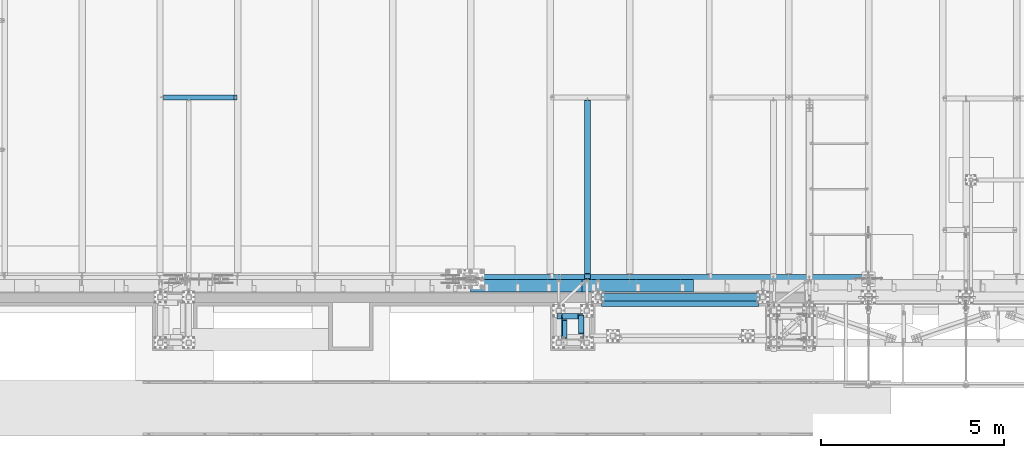
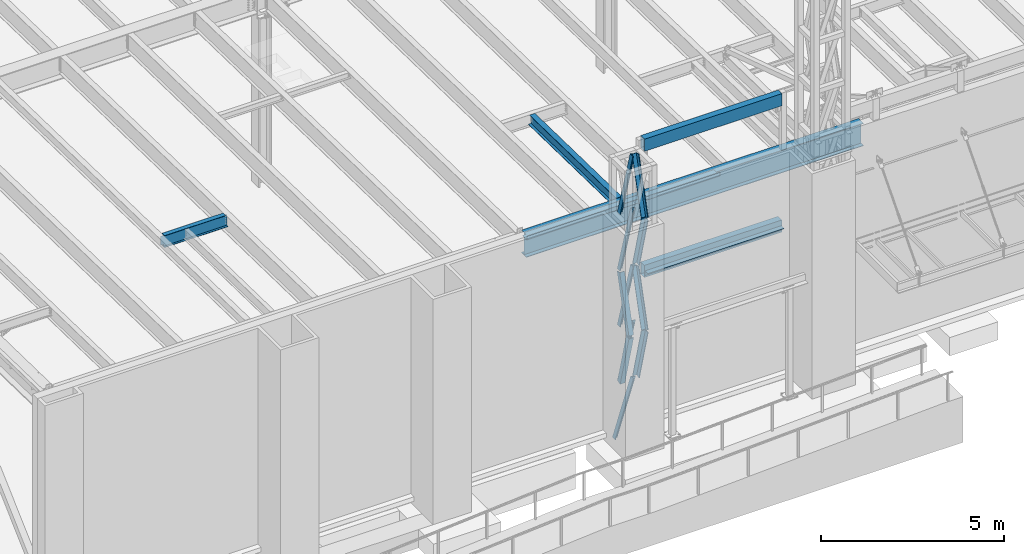
# One storey, part 1039 of 1763: 11 members, 8 beams, 6 elements without a shape of their own.
"""IFC2X3 building model written with IfcOpenShell, lengths in millimetres."""

import ifcopenshell
import ifcopenshell.guid

model = None  # the IFC model being written
_history = None  # IfcOwnerHistory: only IFC2X3 demands one
_inside = {}  # id of a spatial element -> (the spatial element, [elements in it])
_under = {}  # id of a project, library or spatial element -> (it, [spatial elements below it])
_declared = {}  # id of a project -> (the project, [libraries it declares])
_typed = {}  # id of a type object -> (the type object, [elements of that type])
_made_of = {}  # id of a material, layer set ... -> (it, [elements and type objects made of it])


def new_model(schema):
    """Start an empty IFC model of exactly this schema.

    Asked for "IFC4X3", IfcOpenShell would pick the latest addendum, in which some entities
    have other attributes; the version numbers below select the first issue.
    IFC2X3 requires an IfcOwnerHistory on every rooted entity: one is made here for all.
    """
    global model, _history
    if schema == "IFC4X3":
        model = ifcopenshell.file(schema_version=(4, 3, 0, 0))
    else:
        model = ifcopenshell.file(schema=schema)
    _inside.clear()
    _under.clear()
    _declared.clear()
    _typed.clear()
    _made_of.clear()
    _history = None
    if model.schema == "IFC2X3":
        org = make("IfcOrganization", Name="unknown")
        user = make(
            "IfcPersonAndOrganization",
            ThePerson=make("IfcPerson", FamilyName="unknown"),
            TheOrganization=org,
        )
        app = make(
            "IfcApplication",
            ApplicationDeveloper=org,
            Version="unknown",
            ApplicationFullName="unknown",
            ApplicationIdentifier="unknown",
        )
        _history = make(
            "IfcOwnerHistory",
            OwningUser=user,
            OwningApplication=app,
            ChangeAction="ADDED",
            CreationDate=0,
        )
    return model


def make(cls, **values):
    """One entity of the class cls with the attributes given. An attribute that is None is left unset."""
    return model.create_entity(
        cls, **{name: value for name, value in values.items() if value is not None}
    )


def rooted(cls, **values):
    """An entity with a GlobalId (a new one), such as an element, a storey or a relation."""
    return make(cls, GlobalId=ifcopenshell.guid.new(), OwnerHistory=_history, **values)


def si_unit(unit_type, name, prefix=None):
    """IfcSIUnit, for example si_unit("LENGTHUNIT", "METRE", prefix="MILLI")."""
    return make("IfcSIUnit", UnitType=unit_type, Prefix=prefix, Name=name)


def assignment(units):
    """IfcUnitAssignment: the units of a project."""
    return None if units is None else make("IfcUnitAssignment", Units=units)


def point(xyz):
    """IfcCartesianPoint."""
    return None if xyz is None else make("IfcCartesianPoint", Coordinates=xyz)


def direction(xyz):
    """IfcDirection."""
    return None if xyz is None else make("IfcDirection", DirectionRatios=xyz)


def frame(location, z_axis=None, x_axis=None):
    """IfcAxis2Placement3D, a coordinate frame: its origin and axes. An axis left out is left unset."""
    return make(
        "IfcAxis2Placement3D",
        Location=point(location),
        Axis=direction(z_axis),
        RefDirection=direction(x_axis),
    )


def origin_with_axes():
    """The frame at (0, 0, 0) with the z axis (0, 0, 1) and the x axis (1, 0, 0) written out."""
    return frame((0.0, 0.0, 0.0), z_axis=(0.0, 0.0, 1.0), x_axis=(1.0, 0.0, 0.0))


def place(relative_to, where):
    """IfcLocalPlacement: puts the frame where relative to a parent placement (None: the world)."""
    return make(
        "IfcLocalPlacement", PlacementRelTo=relative_to, RelativePlacement=where
    )


def context(
    kind, dimensions, precision=None, world=None, true_north=None, identifier=None
):
    """IfcGeometricRepresentationContext, for example the 3D "Model" context."""
    return make(
        "IfcGeometricRepresentationContext",
        ContextIdentifier=identifier,
        ContextType=kind,
        CoordinateSpaceDimension=dimensions,
        Precision=precision,
        WorldCoordinateSystem=world,
        TrueNorth=true_north,
    )


def subcontext(parent, identifier, kind, view, scale=None):
    """IfcGeometricRepresentationSubContext, for example "Body" below "Model"."""
    return make(
        "IfcGeometricRepresentationSubContext",
        ContextIdentifier=identifier,
        ContextType=kind,
        ParentContext=parent,
        TargetScale=scale,
        TargetView=view,
    )


def project(units=None, contexts=None):
    """IfcProject with its units and contexts."""
    return rooted(
        "IfcProject",
        Name="project",
        RepresentationContexts=contexts,
        UnitsInContext=assignment(units),
    )


def spatial(cls, under=None, at=None, **own):
    """A site, building, storey or space (cls), placed at a placement, below another one or the project."""
    s = rooted(cls, ObjectPlacement=at, **own)
    if under is not None:
        _under.setdefault(under.id(), (under, []))[1].append(s)
    return s


def faces_of(points, faces, orient=None, outer=None):
    """IfcFace entities. A face is a list of loops; a loop is a list of indices into points, from 0.

    orient and outer hold one flag for each loop. By default every Orientation is true, the
    first loop of a face is its IfcFaceOuterBound and the others are IfcFaceBound.
    """
    made = []
    for i, loops in enumerate(faces):
        bounds = []
        for j, loop in enumerate(loops):
            is_outer = j == 0 if outer is None else outer[i][j]
            bounds.append(
                make(
                    "IfcFaceOuterBound" if is_outer else "IfcFaceBound",
                    Bound=make("IfcPolyLoop", Polygon=[points[k] for k in loop]),
                    Orientation=True if orient is None else orient[i][j],
                )
            )
        made.append(make("IfcFace", Bounds=bounds))
    return made


def faceted_brep(points, faces, orient=None, outer=None, voids=None):
    """IfcFacetedBrep: a solid bounded by flat faces; with voids (closed shells), ...WithVoids."""
    shared = [point(p) for p in points]
    hull = make("IfcClosedShell", CfsFaces=faces_of(shared, faces, orient, outer))
    if voids is None:
        return make("IfcFacetedBrep", Outer=hull)
    return make(
        "IfcFacetedBrepWithVoids",
        Outer=hull,
        Voids=[
            make(cls, CfsFaces=faces_of(shared, fs, o, b)) for cls, fs, o, b in voids
        ],
    )


def shape(context_of_items, identifier, shape_type, items):
    """IfcShapeRepresentation: the items that make up one representation, for example the "Body"."""
    return make(
        "IfcShapeRepresentation",
        ContextOfItems=context_of_items,
        RepresentationIdentifier=identifier,
        RepresentationType=shape_type,
        Items=items,
    )


def material(Name=None, Category=None):
    """IfcMaterial."""
    return make("IfcMaterial", Name=Name, Category=Category)


def made_of(thing, what):
    """Note that an element or type object is made of a material, layer set ...; save() writes the relation."""
    if what is not None:
        _made_of.setdefault(what.id(), (what, []))[1].append(thing)
    return thing


def type_object(cls, material=None, **own):
    """A type object (cls), such as IfcWallType, which elements share."""
    return made_of(rooted(cls, **own), material)


def element(
    cls,
    number,
    at=None,
    inside=None,
    cuts=None,
    type_object=None,
    material=None,
    context=None,
    identifier="Body",
    shape_type=None,
    held_by="IfcProductDefinitionShape",
    body=None,
    shapes=None,
    **own,
):
    """One element of the class cls, such as IfcWall. Its Tag is "e" and its number.

    at: its placement. inside: the storey or other place that contains it. cuts: it is an
    opening in that element (IfcRelVoidsElement). A single representation is given by context,
    identifier, shape_type and body (its items); several are given by shapes. held_by: the class
    of the entity that holds the representations. save() writes the other relations.
    """
    e = rooted(cls, Tag="e%d" % number, ObjectPlacement=at, **own)
    if body is not None:
        shapes = [shape(context, identifier, shape_type, body)]
    if shapes is not None:
        e.Representation = make(held_by, Representations=shapes)
    if inside is not None:
        _inside.setdefault(inside.id(), (inside, []))[1].append(e)
    if cuts is not None:
        rooted(
            "IfcRelVoidsElement", RelatingBuildingElement=cuts, RelatedOpeningElement=e
        )
    if type_object is not None:
        _typed.setdefault(type_object.id(), (type_object, []))[1].append(e)
    return made_of(e, material)


def aggregate(whole, parts):
    """IfcRelAggregates: a whole, such as a stair, and the parts it consists of."""
    return rooted("IfcRelAggregates", RelatingObject=whole, RelatedObjects=parts)


def save(model, path):
    """Write the relations noted so far, then the file.

    IfcRelAggregates (storeys below a building ...), IfcRelContainedInSpatialStructure (elements
    in a storey), IfcRelDefinesByType, IfcRelAssociatesMaterial and IfcRelDeclares: one each for
    every whole, place, type object, material and project.
    """
    for whole, parts in _under.values():
        aggregate(whole, parts)
    for where, things in _inside.values():
        rooted(
            "IfcRelContainedInSpatialStructure",
            RelatedElements=things,
            RelatingStructure=where,
        )
    for kind, things in _typed.values():
        rooted("IfcRelDefinesByType", RelatedObjects=things, RelatingType=kind)
    for what, things in _made_of.values():
        rooted("IfcRelAssociatesMaterial", RelatedObjects=things, RelatingMaterial=what)
    for by, libraries in _declared.values():
        rooted("IfcRelDeclares", RelatingContext=by, RelatedDefinitions=libraries)
    model.write(path)


model = new_model("IFC2X3")

# Units and contexts
model_context = context("Model", 3, precision=1e-05, world=origin_with_axes())
body_context = subcontext(model_context, "Body", "Model", "MODEL_VIEW")
ifc_project = project(units=[si_unit("LENGTHUNIT", "METRE", prefix="MILLI"), si_unit("AREAUNIT", "SQUARE_METRE"), si_unit("VOLUMEUNIT", "CUBIC_METRE"), si_unit("MASSUNIT", "GRAM", prefix="KILO"), si_unit("TIMEUNIT", "SECOND"), si_unit("PLANEANGLEUNIT", "RADIAN"), si_unit("SOLIDANGLEUNIT", "STERADIAN"), si_unit("THERMODYNAMICTEMPERATUREUNIT", "DEGREE_CELSIUS"), si_unit("LUMINOUSINTENSITYUNIT", "LUMEN")], contexts=[model_context])

# Site, building, storey
site_placement = place(None, origin_with_axes())
site = spatial("IfcSite", under=ifc_project, at=site_placement, CompositionType="ELEMENT")
building_placement = place(site_placement, origin_with_axes())
building = spatial("IfcBuilding", under=site, at=building_placement, Name="Undefined", CompositionType="ELEMENT")
storey_placement = place(building_placement, origin_with_axes())
storey = spatial("IfcBuildingStorey", under=building, at=storey_placement, Name="Undefined", CompositionType="ELEMENT", Elevation=0.0)

# Assembly, members
assembly_1_placement = place(storey_placement, origin_with_axes())
assembly_1 = element("IfcElementAssembly", 1, at=assembly_1_placement, inside=storey, Name="FRAME", AssemblyPlace="NOTDEFINED", PredefinedType="RIGID_FRAME")
ifc_material_1 = material(Name="STEEL/A36")
member_type = type_object("IfcMemberType", Name="L6X6X7/8", PredefinedType="NOTDEFINED")
member_1_placement = place(assembly_1_placement, frame((-69925.5694630663, -15268.1723843381, 8815.82655407194), z_axis=(0.0, 0.966292662023721, 0.25744609400632), x_axis=(0.0, 0.25744609400632, -0.966292662023721)))
member_1 = element("IfcMember", 2, at=member_1_placement, type_object=member_type, material=ifc_material_1, Name="V. BRACE", ObjectType="L6X6X7/8", context=body_context, shape_type="Brep", body=[
    faceted_brep([(9.09494701772928e-13, -76.2000000000007, -76.2000000000844), (9.09494701772928e-13, 76.2000000000007, -76.2000000000844), (1868.75344729561, 76.1999999999971, -76.1999999992731), (1868.75344729561, -76.1999999999971, -76.1999999992731), (1.81898940354586e-12, -76.2000000000007, -53.9750000000604), (1.81898940354586e-12, 53.9750000000004, -53.9750000000604), (0.0, 53.9750000000004, 76.2000000000771), (0.0, 76.2000000000007, 76.2000000000771), (1868.7534472956, -76.1999999999971, -53.9749999992673), (1868.7534472956, 53.9750000000058, -53.9749999992673), (1868.75344729555, 53.9750000000058, 76.2000000007865), (1868.75344729555, 76.1999999999971, 76.2000000007865)], [[[0, 1, 2, 3]], [[0, 4, 5, 6, 7, 1]], [[5, 4, 8, 9]], [[6, 5, 9, 10]], [[7, 6, 10, 11]], [[1, 7, 11, 2]], [[10, 9, 8, 3, 2, 11]], [[4, 0, 3, 8]]]),
])
member_2_placement = place(assembly_1_placement, frame((-69925.5694630663, -14764.0657847119, 10689.9126145439), z_axis=(0.0, 0.963857514375967, -0.266418265103921), x_axis=(0.0, -0.266418265103921, -0.963857514375967)))
member_2 = element("IfcMember", 3, at=member_2_placement, type_object=member_type, material=ifc_material_1, Name="V. BRACE", ObjectType="L6X6X7/8", context=body_context, shape_type="Brep", body=[
    faceted_brep([(9.09494701772928e-13, -76.2000000000007, -76.2000000000844), (9.09494701772928e-13, 76.2000000000007, -76.2000000000844), (1892.74960718638, 76.1999999999971, -76.2000000004191), (1892.74960718638, -76.1999999999971, -76.2000000004191), (1.81898940354586e-12, -76.2000000000007, -53.9750000000604), (1.81898940354586e-12, 53.9750000000004, -53.9750000000604), (0.0, 53.9750000000004, 76.2000000000771), (0.0, 76.2000000000007, 76.2000000000771), (1892.74960718638, -76.1999999999971, -53.9750000004096), (1892.74960718638, 53.9750000000058, -53.9750000004096), (1892.74960718641, 53.9750000000058, 76.1999999996406), (1892.74960718641, 76.1999999999971, 76.1999999996406)], [[[0, 1, 2, 3]], [[0, 4, 5, 6, 7, 1]], [[5, 4, 8, 9]], [[6, 5, 9, 10]], [[7, 6, 10, 11]], [[1, 7, 11, 2]], [[10, 9, 8, 3, 2, 11]], [[4, 0, 3, 8]]]),
])
member_3_placement = place(assembly_1_placement, frame((-69458.9116892982, -14787.0691081386, 10758.1513109604), z_axis=(-1.0, 0.0, 0.0), x_axis=(0.0, -0.25744609400632, 0.966292662023721)))
member_3 = element("IfcMember", 4, at=member_3_placement, type_object=member_type, material=ifc_material_1, Name="V. BRACE", ObjectType="L6X6X7/8", context=body_context, shape_type="Brep", body=[
    faceted_brep([(9.09494701772928e-13, -76.2000000000007, -76.2000000000844), (9.09494701772928e-13, 76.2000000000007, -76.2000000000844), (1868.75344729561, 76.1999999999971, -76.1999999992731), (1868.75344729561, -76.1999999999971, -76.1999999992731), (1.81898940354586e-12, -76.2000000000007, -53.9750000000604), (1.81898940354586e-12, 53.9750000000004, -53.9750000000604), (0.0, 53.9750000000004, 76.2000000000771), (0.0, 76.2000000000007, 76.2000000000771), (1868.7534472956, -76.1999999999971, -53.9749999992673), (1868.7534472956, 53.9750000000058, -53.9749999992673), (1868.75344729555, 53.9750000000058, 76.2000000007865), (1868.75344729555, 76.1999999999971, 76.2000000007865)], [[[0, 1, 2, 3]], [[0, 4, 5, 6, 7, 1]], [[5, 4, 8, 9]], [[6, 5, 9, 10]], [[7, 6, 10, 11]], [[1, 7, 11, 2]], [[10, 9, 8, 3, 2, 11]], [[4, 0, 3, 8]]]),
])
member_4_placement = place(assembly_1_placement, frame((-69458.911689305, -15268.3288504456, 12613.6591825793), z_axis=(-1.0, 0.0, 0.0), x_axis=(0.0, 0.266418265103921, 0.963857514375967)))
member_4 = element("IfcMember", 5, at=member_4_placement, type_object=member_type, material=ifc_material_1, Name="V. BRACE", ObjectType="L6X6X7/8", context=body_context, shape_type="Brep", body=[
    faceted_brep([(9.09494701772928e-13, -76.2000000000007, -76.2000000000844), (9.09494701772928e-13, 76.2000000000007, -76.2000000000844), (1892.74960718638, 76.1999999999971, -76.2000000004191), (1892.74960718638, -76.1999999999971, -76.2000000004191), (1.81898940354586e-12, -76.2000000000007, -53.9750000000604), (1.81898940354586e-12, 53.9750000000004, -53.9750000000604), (0.0, 53.9750000000004, 76.2000000000771), (0.0, 76.2000000000007, 76.2000000000771), (1892.74960718638, -76.1999999999971, -53.9750000004096), (1892.74960718638, 53.9750000000058, -53.9750000004096), (1892.74960718641, 53.9750000000058, 76.1999999996406), (1892.74960718641, 76.1999999999971, 76.1999999996406)], [[[0, 1, 2, 3]], [[0, 4, 5, 6, 7, 1]], [[5, 4, 8, 9]], [[6, 5, 9, 10]], [[7, 6, 10, 11]], [[1, 7, 11, 2]], [[10, 9, 8, 3, 2, 11]], [[4, 0, 3, 8]]]),
])
member_5_placement = place(assembly_1_placement, frame((-69902.4954360968, -14731.9992675181, 10714.8312500468), z_axis=(0.0, -1.0, 0.0), x_axis=(0.218804753982199, 0.0, 0.975768660920604)))
member_5 = element("IfcMember", 6, at=member_5_placement, type_object=member_type, material=ifc_material_1, Name="V. BRACE", ObjectType="L6X6X7/8", context=body_context, shape_type="Brep", body=[
    faceted_brep([(9.09494701772928e-13, 76.2000000000007, -76.2000000000844), (0.0, 76.2000000000007, 76.2000000000771), (1920.5820240066, 76.2000000000007, 76.1999999998516), (1920.58202400652, 76.2000000000007, -76.2000000004628), (0.0, 53.9750000000004, 76.2000000000771), (1920.5820240066, 53.9750000000004, 76.1999999998516), (1.81898940354586e-12, 53.9750000000004, -53.9750000000604), (1920.58202400653, 53.9750000000004, -53.9750000004133), (1.81898940354586e-12, -76.2000000000007, -53.9750000000604), (1920.58202400653, -76.2000000000007, -53.9750000004133), (9.09494701772928e-13, -76.2000000000007, -76.2000000000844), (1920.58202400652, -76.2000000000007, -76.2000000004628)], [[[0, 1, 2, 3]], [[1, 4, 5, 2]], [[4, 6, 7, 5]], [[6, 8, 9, 7]], [[8, 10, 11, 9]], [[10, 0, 3, 11]], [[5, 7, 9, 11, 3, 2]], [[10, 8, 6, 4, 1, 0]]]),
])
member_6_placement = place(assembly_1_placement, frame((-69902.49543609, -14731.9992675181, 8840.78750004684), z_axis=(0.0, -1.0, 0.0), x_axis=(0.218804753982199, 0.0, 0.975768660920604)))
member_6 = element("IfcMember", 7, at=member_6_placement, type_object=member_type, material=ifc_material_1, Name="V. BRACE", ObjectType="L6X6X7/8", context=body_context, shape_type="Brep", body=[
    faceted_brep([(9.09494701772928e-13, 76.2000000000007, -76.2000000000844), (0.0, 76.2000000000007, 76.2000000000771), (1920.5820240066, 76.2000000000007, 76.1999999998516), (1920.58202400652, 76.2000000000007, -76.2000000004628), (0.0, 53.9750000000004, 76.2000000000771), (1920.5820240066, 53.9750000000004, 76.1999999998516), (1.81898940354586e-12, 53.9750000000004, -53.9750000000604), (1920.58202400653, 53.9750000000004, -53.9750000004133), (1.81898940354586e-12, -76.2000000000007, -53.9750000000604), (1920.58202400653, -76.2000000000007, -53.9750000004133), (9.09494701772928e-13, -76.2000000000007, -76.2000000000844), (1920.58202400652, -76.2000000000007, -76.2000000004628)], [[[0, 1, 2, 3]], [[1, 4, 5, 2]], [[4, 6, 7, 5]], [[6, 8, 9, 7]], [[8, 10, 11, 9]], [[10, 0, 3, 11]], [[5, 7, 9, 11, 3, 2]], [[10, 8, 6, 4, 1, 0]]]),
])
member_7_placement = place(assembly_1_placement, frame((-69458.9116892846, -14787.0691081386, 7010.06381096041), z_axis=(-1.0, 0.0, 0.0), x_axis=(0.0, -0.25744609400632, 0.966292662023721)))
member_7 = element("IfcMember", 8, at=member_7_placement, type_object=member_type, material=ifc_material_1, Name="V. BRACE", ObjectType="L6X6X7/8", context=body_context, shape_type="Brep", body=[
    faceted_brep([(9.09494701772928e-13, -76.2000000000007, -76.2000000000844), (9.09494701772928e-13, 76.2000000000007, -76.2000000000844), (1868.75344729561, 76.1999999999971, -76.1999999992731), (1868.75344729561, -76.1999999999971, -76.1999999992731), (1.81898940354586e-12, -76.2000000000007, -53.9750000000604), (1.81898940354586e-12, 53.9750000000004, -53.9750000000604), (0.0, 53.9750000000004, 76.2000000000771), (0.0, 76.2000000000007, 76.2000000000771), (1868.7534472956, -76.1999999999971, -53.9749999992673), (1868.7534472956, 53.9750000000058, -53.9749999992673), (1868.75344729555, 53.9750000000058, 76.2000000007865), (1868.75344729555, 76.1999999999971, 76.2000000007865)], [[[0, 1, 2, 3]], [[0, 4, 5, 6, 7, 1]], [[5, 4, 8, 9]], [[6, 5, 9, 10]], [[7, 6, 10, 11]], [[1, 7, 11, 2]], [[10, 9, 8, 3, 2, 11]], [[4, 0, 3, 8]]]),
])
member_8_placement = place(assembly_1_placement, frame((-69458.9116892914, -15268.3288504456, 8865.5716825793), z_axis=(-1.0, 0.0, 0.0), x_axis=(0.0, 0.266418265103921, 0.963857514375967)))
member_8 = element("IfcMember", 9, at=member_8_placement, type_object=member_type, material=ifc_material_1, Name="V. BRACE", ObjectType="L6X6X7/8", context=body_context, shape_type="Brep", body=[
    faceted_brep([(9.09494701772928e-13, -76.2000000000007, -76.2000000000844), (9.09494701772928e-13, 76.2000000000007, -76.2000000000844), (1892.74960718638, 76.1999999999971, -76.2000000004191), (1892.74960718638, -76.1999999999971, -76.2000000004191), (1.81898940354586e-12, -76.2000000000007, -53.9750000000604), (1.81898940354586e-12, 53.9750000000004, -53.9750000000604), (0.0, 53.9750000000004, 76.2000000000771), (0.0, 76.2000000000007, 76.2000000000771), (1892.74960718638, -76.1999999999971, -53.9750000004096), (1892.74960718638, 53.9750000000058, -53.9750000004096), (1892.74960718641, 53.9750000000058, 76.1999999996406), (1892.74960718641, 76.1999999999971, 76.1999999996406)], [[[0, 1, 2, 3]], [[0, 4, 5, 6, 7, 1]], [[5, 4, 8, 9]], [[6, 5, 9, 10]], [[7, 6, 10, 11]], [[1, 7, 11, 2]], [[10, 9, 8, 3, 2, 11]], [[4, 0, 3, 8]]]),
])
member_9_placement = place(assembly_1_placement, frame((-69902.6429119776, -14731.9992675181, 12588.8750000571), z_axis=(0.0, -1.0, 0.0), x_axis=(0.219355453919122, 0.0, 0.975645009640256)))
member_9 = element("IfcMember", 10, at=member_9_placement, type_object=member_type, material=ifc_material_1, Name="V. BRACE", ObjectType="L6X6X7/8", context=body_context, shape_type="Brep", body=[
    faceted_brep([(9.09494701772928e-13, 76.2000000000007, -76.2000000000844), (0.0, 76.2000000000007, 76.2000000000771), (1858.18097968706, 76.1999999878753, 76.2000000000007), (1858.18097968706, 76.1999999878753, -76.2000000000007), (0.0, 53.9750000000004, 76.2000000000771), (1858.1809796871, 53.9749999877386, 76.2000000000007), (1.81898940354586e-12, 53.9750000000004, -53.9750000000604), (1858.1809796871, 53.9749999877386, -53.9750000000004), (1.81898940354586e-12, -76.2000000000007, -53.9750000000604), (1858.18097968729, -76.2000000130356, -53.9750000000004), (9.09494701772928e-13, -76.2000000000007, -76.2000000000844), (1858.18097968729, -76.2000000130356, -76.2000000000007)], [[[0, 1, 2, 3]], [[1, 4, 5, 2]], [[4, 6, 7, 5]], [[6, 8, 9, 7]], [[8, 10, 11, 9]], [[10, 0, 3, 11]], [[5, 7, 9, 11, 3, 2]], [[10, 8, 6, 4, 1, 0]]]),
])
member_10_placement = place(assembly_1_placement, frame((-69902.4954360831, -14731.9992675181, 6966.74375004683), z_axis=(0.0, -1.0, 0.0), x_axis=(0.218804753982199, 0.0, 0.975768660920604)))
member_10 = element("IfcMember", 11, at=member_10_placement, type_object=member_type, material=ifc_material_1, Name="V. BRACE", ObjectType="L6X6X7/8", context=body_context, shape_type="Brep", body=[
    faceted_brep([(9.09494701772928e-13, 76.2000000000007, -76.2000000000844), (0.0, 76.2000000000007, 76.2000000000771), (1920.5820240066, 76.2000000000007, 76.1999999998516), (1920.58202400652, 76.2000000000007, -76.2000000004628), (0.0, 53.9750000000004, 76.2000000000771), (1920.5820240066, 53.9750000000004, 76.1999999998516), (1.81898940354586e-12, 53.9750000000004, -53.9750000000604), (1920.58202400653, 53.9750000000004, -53.9750000004133), (1.81898940354586e-12, -76.2000000000007, -53.9750000000604), (1920.58202400653, -76.2000000000007, -53.9750000004133), (9.09494701772928e-13, -76.2000000000007, -76.2000000000844), (1920.58202400652, -76.2000000000007, -76.2000000004628)], [[[0, 1, 2, 3]], [[1, 4, 5, 2]], [[4, 6, 7, 5]], [[6, 8, 9, 7]], [[8, 10, 11, 9]], [[10, 0, 3, 11]], [[5, 7, 9, 11, 3, 2]], [[10, 8, 6, 4, 1, 0]]]),
])
member_11_placement = place(assembly_1_placement, frame((-70078.0368845901, -14731.9992675181, 5067.3), z_axis=(0.0, -1.0, 0.0), x_axis=(0.30006571093599, 0.0, 0.953918533796508)))
member_11 = element("IfcMember", 12, at=member_11_placement, type_object=member_type, material=ifc_material_1, Name="V. BRACE", ObjectType="L6X6X7/8", context=body_context, shape_type="Brep", body=[
    faceted_brep([(63.9100772377278, 76.1999999996478, -76.2000000000007), (63.9100772377278, 76.1999999996478, 76.2000000000007), (1991.20122200253, 76.1999999978143, 76.2000000000007), (1991.20122200253, 76.1999999978143, -76.2000000000007), (63.9100772377224, 53.9749999997293, 76.2000000000007), (1991.2012220025, 53.9749999978958, 76.2000000000007), (63.9100772377224, 53.9749999997293, -53.9750000000004), (1991.2012220025, 53.9749999978958, -53.9750000000004), (63.9100772376914, -76.1999999997788, -53.9750000000004), (1991.20122200235, -76.2000000016124, -53.9750000000004), (63.9100772376914, -76.1999999997788, -76.2000000000007), (1991.20122200235, -76.2000000016124, -76.2000000000007)], [[[0, 1, 2, 3]], [[1, 4, 5, 2]], [[4, 6, 7, 5]], [[6, 8, 9, 7]], [[8, 10, 11, 9]], [[10, 0, 3, 11]], [[5, 7, 9, 11, 3, 2]], [[10, 8, 6, 4, 1, 0]]]),
])
aggregate(assembly_1, [member_1, member_2, member_3, member_4, member_5, member_6, member_7, member_8, member_9, member_10, member_11])

# Assembly, beam
assembly_2_placement = place(storey_placement, origin_with_axes())
assembly_2 = element("IfcElementAssembly", 13, at=assembly_2_placement, inside=storey, Name="BEAM", AssemblyPlace="NOTDEFINED", PredefinedType="RIGID_FRAME")
ifc_material_2 = material()
beam_type_1 = type_object("IfcBeamType", Name="HSS16X8X1/4", PredefinedType="NOTDEFINED")
beam_1_placement = place(assembly_2_placement, frame((-68925.9577158888, -14208.1264769908, 14262.1), z_axis=(0.0, 0.0, 1.0), x_axis=(1.0, 0.0, 0.0)))
beam_1 = element("IfcBeam", 14, at=beam_1_placement, type_object=beam_type_1, material=ifc_material_2, Name="BEAM", ObjectType="HSS16X8X1/4", context=body_context, shape_type="Brep", body=[
    faceted_brep([(9.52500000002328, 95.25, -196.85), (9.52500000002328, -95.25, -196.85), (4349.75034179688, -95.25, -196.85), (4349.75034179688, 95.25, -196.85), (9.52500000002328, -95.25, 196.85), (4349.75034179688, -95.25, 196.85), (9.52500000002328, 95.25, 196.85), (4349.75034179688, 95.25, 196.85), (9.52500000002328, 101.6, -203.200000000001), (9.52500000002328, 101.6, 203.200000000001), (4349.75034179688, 101.6, 203.200000000001), (4349.75034179688, 101.6, -203.200000000001), (9.52500000002328, -101.6, 203.200000000001), (4349.75034179688, -101.6, 203.200000000001), (9.52500000002328, -101.6, -203.200000000001), (4349.75034179688, -101.6, -203.200000000001)], [[[0, 1, 2, 3]], [[1, 4, 5, 2]], [[4, 6, 7, 5]], [[6, 0, 3, 7]], [[8, 9, 10, 11]], [[9, 12, 13, 10]], [[12, 14, 15, 13]], [[14, 8, 11, 15]], [[13, 15, 11, 10], [5, 7, 3, 2]], [[14, 12, 9, 8], [6, 4, 1, 0]]]),
])
aggregate(assembly_2, [beam_1])

assembly_3_placement = place(storey_placement, origin_with_axes())
assembly_3 = element("IfcElementAssembly", 15, at=assembly_3_placement, inside=storey, Name="BEAM", AssemblyPlace="NOTDEFINED", PredefinedType="RIGID_FRAME")
beam_2_placement = place(assembly_3_placement, frame((-68925.9577158888, -14208.1264769908, 10045.7), z_axis=(0.0, 0.0, 1.0), x_axis=(1.0, 0.0, 0.0)))
beam_2 = element("IfcBeam", 16, at=beam_2_placement, type_object=beam_type_1, material=ifc_material_2, Name="BEAM", ObjectType="HSS16X8X1/4", context=body_context, shape_type="Brep", body=[
    faceted_brep([(9.52500000002328, 95.25, -196.85), (9.52500000002328, -95.25, -196.85), (4349.75034179688, -95.25, -196.85), (4349.75034179688, 95.25, -196.85), (9.52500000002328, -95.25, 196.85), (4349.75034179688, -95.25, 196.85), (9.52500000002328, 95.25, 196.85), (4349.75034179688, 95.25, 196.85), (9.52500000002328, 101.6, -203.200000000001), (9.52500000002328, 101.6, 203.200000000001), (4349.75034179688, 101.6, 203.200000000001), (4349.75034179688, 101.6, -203.200000000001), (9.52500000002328, -101.6, 203.200000000001), (4349.75034179688, -101.6, 203.200000000001), (9.52500000002328, -101.6, -203.200000000001), (4349.75034179688, -101.6, -203.200000000001)], [[[0, 1, 2, 3]], [[1, 4, 5, 2]], [[4, 6, 7, 5]], [[6, 0, 3, 7]], [[8, 9, 10, 11]], [[9, 12, 13, 10]], [[12, 14, 15, 13]], [[14, 8, 11, 15]], [[13, 15, 11, 10], [5, 7, 3, 2]], [[14, 12, 9, 8], [6, 4, 1, 0]]]),
])

assembly_4_placement = place(storey_placement, origin_with_axes())
assembly_4 = element("IfcElementAssembly", 17, at=assembly_4_placement, inside=storey, Name="BEAM", AssemblyPlace="NOTDEFINED", PredefinedType="RIGID_FRAME")
ifc_material_3 = material(Name="STEEL/A992")
beam_type_2 = type_object("IfcBeamType", Name="W14X30", PredefinedType="NOTDEFINED")
beam_3_placement = place(assembly_4_placement, frame((-69290.6368842947, -13719.6831430452, 12028.5259948847), z_axis=(0.0, 0.0209013539966291, 0.999781542838788), x_axis=(0.0, 0.999781542776098, -0.0209013569953182)))
beam_3 = element("IfcBeam", 18, at=beam_3_placement, type_object=beam_type_2, material=ifc_material_3, Name="BEAM", ObjectType="W14X30", context=body_context, shape_type="Brep", body=[
    faceted_brep([(137.832215400145, -3.17500000000291, 125.152501678551), (137.832215400145, 3.17500000000291, 125.152501678551), (20.9157867656977, 3.17500000000291, 125.152501678487), (20.9157867656977, -3.17500000000291, 125.152501678487), (142.692294918188, -3.17500000000291, 126.11923160114), (142.692294918188, 3.17500000000291, 126.11923160114), (146.812471386336, -3.17500000000291, 128.87224550162), (146.812471386336, 3.17500000000291, 128.87224550162), (149.565485286814, -3.17500000000291, 132.992421969775), (149.565485286814, 3.17500000000291, 132.992421969775), (150.5322152094, -3.17500000000291, 137.85250148782), (150.5322152094, 3.17500000000291, 137.85250148782), (150.53221520938, -85.7250000000058, 176.21250000006), (150.53221520938, 85.7250000000058, 176.21250000006), (150.532215209383, 85.7250000000058, 166.687500000062), (150.532215209383, 3.17500000000291, 166.687500000062), (150.532215209383, -3.17500000000291, 166.687500000062), (150.532215209383, -85.7250000000058, 166.687500000062), (27.0169710904029, -3.17500000000291, -166.687499999971), (27.0169710904029, -85.7250000000058, -166.687499999971), (4969.20227449865, -85.7250000000058, -166.687499997337), (4969.20227449865, -3.17500000000291, -166.687499997337), (27.2160999978823, -85.7250000000058, -176.212499999969), (4969.40140340613, -85.7250000000058, -176.212499997337), (27.2160999978823, 85.7250000000058, -176.212499999969), (4969.40140340613, 85.7250000000058, -176.212499997337), (27.0169710904029, 85.7250000000058, -166.687499999971), (4969.20227449865, 85.7250000000058, -166.687499997337), (27.0169710904029, 3.17500000000291, -166.687499999971), (4969.20227449865, 3.17500000000291, -166.687499997337), (4962.70283235871, 3.17500000000291, 144.202501694288), (4962.70283235871, -3.17500000000291, 144.202501694288), (4908.56751842578, 3.17500000000291, 144.202501694259), (4908.56751842578, -3.17500000000291, 144.202501694259), (4903.70743890774, 3.17500000000291, 145.169231616845), (4903.70743890774, -3.17500000000291, 145.169231616845), (4899.58726243958, 3.17500000000291, 147.922245517319), (4899.58726243958, -3.17500000000291, 147.922245517319), (4896.8342485391, 3.17500000000291, 152.042421985469), (4896.8342485391, -3.17500000000291, 152.042421985469), (4895.86751861651, 3.17500000000291, 156.902501503513), (4895.86751861651, -3.17500000000291, 156.902501503513), (4895.8675186165, -85.7250000000058, 176.212500002588), (4895.86751861651, -85.7250000000058, 166.68750000259), (4895.86751861651, -3.17500000000291, 166.68750000259), (4895.86751861651, 3.17500000000291, 166.68750000259), (4895.86751861651, 85.7250000000058, 166.68750000259), (4895.8675186165, 85.7250000000058, 176.212500002588)], [[[0, 1, 2, 3]], [[4, 5, 1, 0]], [[6, 7, 5, 4]], [[8, 9, 7, 6]], [[10, 11, 9, 8]], [[12, 13, 14, 15, 11, 10, 16, 17]], [[18, 19, 20, 21]], [[19, 22, 23, 20]], [[22, 24, 25, 23]], [[24, 26, 27, 25]], [[26, 28, 29, 27]], [[21, 20, 23, 25, 27, 29, 30, 31]], [[31, 30, 32, 33]], [[33, 32, 34, 35]], [[35, 34, 36, 37]], [[37, 36, 38, 39]], [[39, 38, 40, 41]], [[42, 43, 44, 41, 40, 45, 46, 47]], [[43, 42, 12, 17]], [[44, 43, 17, 16]], [[8, 6, 4, 0, 3, 18, 21, 31, 33, 35, 37, 39, 41, 44, 16, 10]], [[28, 26, 24, 22, 19, 18, 3, 2]], [[45, 40, 38, 36, 34, 32, 30, 29, 28, 2, 1, 5, 7, 9, 11, 15]], [[46, 45, 15, 14]], [[47, 46, 14, 13]], [[42, 47, 13, 12]]]),
])
aggregate(assembly_4, [beam_3])

assembly_5_placement = place(storey_placement, origin_with_axes())
assembly_5 = element("IfcElementAssembly", 19, at=assembly_5_placement, inside=storey, Name="BEAM", AssemblyPlace="NOTDEFINED", PredefinedType="RIGID_FRAME")
beam_type_3 = type_object("IfcBeamType", Name="W16X26", PredefinedType="NOTDEFINED")
beam_4_placement = place(assembly_5_placement, frame((-80996.4087022698, -8740.32782160123, 11900.6539815799), z_axis=(0.0, 0.0, 1.0), x_axis=(1.0, 0.0, 0.0)))
beam_4 = element("IfcBeam", 20, at=beam_4_placement, type_object=beam_type_3, material=ifc_material_3, Name="BEAM", ObjectType="W16X26", context=body_context, shape_type="Brep", body=[
    faceted_brep([(15.875, -3.17499999999927, -124.085000000323), (15.875, 3.17499999999927, -124.085000000323), (85.7250001907378, 3.17499999999927, -124.085000000323), (85.7250001907378, -3.17499999999927, -124.085000000323), (90.5850797087769, 3.17499999999927, -125.05172992291), (90.5850797087769, -3.17499999999927, -125.05172992291), (94.7052561769378, 3.17499999999927, -127.804743823388), (94.7052561769378, -3.17499999999927, -127.804743823388), (97.458270077419, 3.17499999999927, -131.924920291542), (97.458270077419, -3.17499999999927, -131.924920291542), (98.4250000000029, -3.17499999999927, -136.784999809588), (98.4250000000029, 3.17499999999927, -136.784999809588), (98.4250000000029, 3.17499999999927, -190.5), (98.4250000000029, 69.8500000000004, -190.5), (98.4250000000029, 69.8500000000004, -200.025), (98.4250000000029, -69.8500000000004, -200.025), (98.4250000000029, -69.8500000000004, -190.5), (98.4250000000029, -3.17499999999927, -190.5), (98.4250000000029, 3.17499999999927, 190.5), (98.4250000000029, 69.8500000000004, 190.5), (2026.33035714286, 69.8500000000004, 190.5), (2026.33035714286, 3.17499999999927, 190.5), (85.7250001907378, -3.17499999999927, 168.015001678144), (85.7250001907378, 3.17499999999927, 168.015001678144), (15.875, 3.17499999999927, 168.015001678144), (15.875, -3.17499999999927, 168.015001678144), (90.5850797087769, -3.17499999999927, 168.981731600732), (90.5850797087769, 3.17499999999927, 168.981731600732), (94.7052561769378, -3.17499999999927, 171.73474550121), (94.7052561769378, 3.17499999999927, 171.73474550121), (97.458270077419, -3.17499999999927, 175.854921969363), (97.458270077419, 3.17499999999927, 175.854921969363), (98.4250000000029, -3.17499999999927, 180.71500148741), (98.4250000000029, 3.17499999999927, 180.71500148741), (98.4250000000029, -69.8500000000004, 200.025), (98.4250000000029, 69.8500000000004, 200.025), (98.4250000000029, -3.17499999999927, 190.5), (98.4250000000029, -69.8500000000004, 190.5), (2026.33035714286, -3.17499999999927, 190.5), (2026.33035714286, -69.8500000000004, 190.5), (2026.33035714286, -69.8500000000004, 200.025), (2026.33035714286, 69.8500000000004, 200.025), (2026.33035714286, -3.17499999999927, 180.715001487704), (2026.33035714286, 3.17499999999927, 180.715001487704), (2027.29708706544, -3.17499999999927, 175.854921969658), (2027.29708706544, 3.17499999999927, 175.854921969658), (2030.05010096592, -3.17499999999927, 171.734745501504), (2030.05010096592, 3.17499999999927, 171.734745501504), (2034.17027743408, -3.17499999999927, 168.981731601027), (2034.17027743408, 3.17499999999927, 168.981731601027), (2039.03035695212, -3.17499999999927, 168.015001678439), (2039.03035695212, 3.17499999999927, 168.015001678439), (2108.88035714286, -3.17499999999927, 168.015001678439), (2108.88035714286, 3.17499999999927, 168.015001678439), (2108.88035714286, -3.17499999999927, -190.5), (2108.88035714286, -69.8500000000004, -190.5), (2108.88035714286, -69.8500000000004, -200.025), (2108.88035714286, 69.8500000000004, -200.025), (2108.88035714286, 69.8500000000004, -190.5), (2108.88035714286, 3.17499999999927, -190.5)], [[[0, 1, 2, 3]], [[3, 2, 4, 5]], [[5, 4, 6, 7]], [[7, 6, 8, 9]], [[10, 11, 12, 13, 14, 15, 16, 17]], [[9, 8, 11, 10]], [[18, 19, 20, 21]], [[22, 23, 24, 25]], [[26, 27, 23, 22]], [[28, 29, 27, 26]], [[30, 31, 29, 28]], [[32, 33, 31, 30]], [[34, 35, 19, 18, 33, 32, 36, 37]], [[37, 36, 38, 39]], [[34, 37, 39, 40]], [[35, 34, 40, 41]], [[19, 35, 41, 20]], [[40, 39, 38, 42, 43, 21, 20, 41]], [[44, 45, 43, 42]], [[46, 47, 45, 44]], [[48, 49, 47, 46]], [[50, 51, 49, 48]], [[52, 53, 51, 50]], [[54, 55, 56, 57, 58, 59, 53, 52]], [[55, 54, 17, 16]], [[56, 55, 16, 15]], [[57, 56, 15, 14]], [[58, 57, 14, 13]], [[59, 58, 13, 12]], [[6, 4, 2, 1, 24, 23, 27, 29, 31, 33, 18, 21, 43, 45, 47, 49, 51, 53, 59, 12, 11, 8]], [[25, 24, 1, 0]], [[54, 52, 50, 48, 46, 44, 42, 38, 36, 32, 30, 28, 26, 22, 25, 0, 3, 5, 7, 9, 10, 17]]]),
])
aggregate(assembly_5, [beam_4])

# Beam
beam_type_4 = type_object("IfcBeamType", Name="L6X6X3/8", PredefinedType="NOTDEFINED")
beam_5_placement = place(assembly_3_placement, frame((-68900.5577158888, -14385.9264769908, 9986.9625), z_axis=(0.0, -1.0, 0.0), x_axis=(1.0, 0.0, 0.0)))
beam_5 = element("IfcBeam", 21, at=beam_5_placement, type_object=beam_type_4, material=ifc_material_1, Name="ANGLE", ObjectType="L6X6X3/8", context=body_context, shape_type="Brep", body=[
    faceted_brep([(9.09494701772928e-13, 76.2000000000007, -76.2000000000844), (0.0, 76.2000000000007, 76.2000000000771), (4308.47534179688, 76.2000000000007, 76.2000000000007), (4308.47534179688, 76.2000000000007, -76.2000000000007), (0.0, 66.6749999999993, 76.2000000000007), (4308.47534179688, 66.6749999999993, 76.2000000000007), (0.0, 66.6749999999993, -66.6749999999993), (4308.47534179688, 66.6749999999993, -66.6749999999993), (0.0, -76.2000000000007, -66.6749999999993), (4308.47534179688, -76.2000000000007, -66.6749999999993), (9.09494701772928e-13, -76.2000000000007, -76.2000000000844), (4308.47534179688, -76.2000000000007, -76.2000000000007)], [[[0, 1, 2, 3]], [[1, 4, 5, 2]], [[4, 6, 7, 5]], [[6, 8, 9, 7]], [[8, 10, 11, 9]], [[10, 0, 3, 11]], [[5, 7, 9, 11, 3, 2]], [[10, 8, 6, 4, 1, 0]]]),
])

aggregate(assembly_3, [beam_5, beam_2])

# Assembly, beams
assembly_6_placement = place(storey_placement, origin_with_axes())
assembly_6 = element("IfcElementAssembly", 22, at=assembly_6_placement, inside=storey, Name="BEAM", AssemblyPlace="NOTDEFINED", PredefinedType="RIGID_FRAME")
beam_type_5 = type_object("IfcBeamType", PredefinedType="NOTDEFINED")
beam_6_placement = place(assembly_6_placement, frame((-70963.8622736984, -13728.6998186171, 12207.875), z_axis=(-1.0, 0.0, 0.0), x_axis=(0.0, -1.0, 0.0)))
beam_6 = element("IfcBeam", 23, at=beam_6_placement, type_object=beam_type_5, material=ifc_material_1, Name="BENT_PLATE", context=body_context, shape_type="Brep", body=[
    faceted_brep([(101.600186157239, -3.17499999999927, 1412.875), (101.600186157239, 3.17499999999927, 1412.875), (0.0, 3.17499999999927, 1412.875), (0.0, -3.17499999999927, 1412.875), (101.600186157239, -3.17499999999927, 1524.0), (101.600186157239, 3.17499999999927, 1524.0), (336.550018310547, -3.17499999999927, -1524.0), (0.0, -3.17499999999927, -1523.99999999999), (0.0, 3.17499999999927, -1523.99999999999), (330.200016784669, 3.17499999999927, -1524.0), (330.19998779297, 123.824998474123, -1524.0), (336.549987792969, 123.825000000001, -1524.0), (330.200016784669, 3.17499999999927, 1524.0), (330.19998779297, 123.824998474123, 1524.0), (336.549987792969, 123.825000000001, 1524.0), (336.550018310547, -3.17499999999927, 1524.0)], [[[0, 1, 2, 3]], [[4, 5, 1, 0]], [[6, 7, 8, 9, 10, 11]], [[9, 12, 13, 10]], [[14, 11, 10, 13]], [[15, 6, 11, 14]], [[3, 7, 6, 15, 4, 0]], [[8, 7, 3, 2]], [[12, 9, 8, 2, 1, 5]], [[15, 14, 13, 12, 5, 4]]]),
])
beam_7_placement = place(assembly_6_placement, frame((-67915.8622736984, -13728.6998186171, 12207.875), z_axis=(-1.0, 0.0, 0.0), x_axis=(0.0, -1.0, 0.0)))
beam_7 = element("IfcBeam", 24, at=beam_7_placement, type_object=beam_type_5, material=ifc_material_1, Name="BENT_PLATE", context=body_context, shape_type="Brep", body=[
    faceted_brep([(0.0, -3.17499999999927, -1523.99999999999), (0.0, -3.17499999999927, 1524.0), (0.0, 3.17499999999927, 1524.0), (0.0, 3.17499999999927, -1523.99999999999), (330.200016784669, 3.17499999999927, 1524.0), (330.200016784669, 3.17499999999927, -1524.0), (336.550018310547, -3.17499999999927, -1524.0), (336.550018310547, -3.17499999999927, 1524.0), (330.19998779297, 123.824998474123, 1524.0), (330.19998779297, 123.824998474123, -1524.0), (336.549987792969, 123.825000000001, 1524.0), (336.549987792969, 123.825000000001, -1524.0)], [[[0, 1, 2, 3]], [[3, 2, 4, 5]], [[1, 0, 6, 7]], [[5, 4, 8, 9]], [[4, 2, 1, 7, 10, 8]], [[7, 6, 11, 10]], [[6, 0, 3, 5, 9, 11]], [[10, 11, 9, 8]]]),
])
beam_type_6 = type_object("IfcBeamType", Name="W30X108", PredefinedType="NOTDEFINED")
beam_8_placement = place(assembly_6_placement, frame((-72491.0372736984, -13715.9998186171, 11825.2875), z_axis=(0.0, 0.0, 1.0), x_axis=(1.0, 0.0, 0.0)))
beam_8 = element("IfcBeam", 25, at=beam_8_placement, type_object=beam_type_6, material=ifc_material_3, Name="BEAM", ObjectType="W30X108", context=body_context, shape_type="Brep", body=[
    faceted_brep([(10756.9, 133.35, -360.775), (10496.55025, 133.35, -360.775), (10496.55025, 7.44374999999854, -360.775), (10756.9, 7.44374999999854, -360.775), (10496.55025, 7.44374999999854, -360.362499999999), (10496.55025, 133.35, -360.362499999999), (10756.9, 7.44374999999854, -360.362499999999), (114.300000000003, -133.35, -379.4125), (114.300000000003, -133.35, -360.362499999999), (114.300000000003, -7.14374999999927, -360.362499999999), (114.300000000003, -7.14374999999927, 360.362499999999), (114.300000000003, -133.35, 360.362499999999), (114.300000000003, -133.35, 379.4125), (114.300000000003, 133.35, 379.4125), (114.300000000003, 133.35, 360.362499999999), (114.300000000003, 7.14374999999927, 360.362499999999), (114.300000000003, 7.14374999999927, -360.362499999999), (114.300000000003, 133.35, -360.362499999999), (114.300000000003, 133.35, -379.4125), (10756.9, 133.35, -379.4125), (10756.9, -133.35, -379.4125), (10756.9, -133.35, -360.362499999999), (10756.9, -7.14374999999927, -360.362499999999), (10756.9, -7.14374999999927, 360.362499999999), (10756.9, -133.35, 360.362499999999), (10756.9, -133.35, 379.4125), (10756.9, 133.35, 379.4125), (10756.9, 133.35, 360.362499999999), (10756.9, 7.14374999999927, 360.362499999999), (10756.9, 7.14374999999927, -360.362499999999)], [[[0, 1, 2, 3]], [[4, 2, 1, 5]], [[6, 3, 2, 4]], [[7, 8, 9, 10, 11, 12, 13, 14, 15, 16, 17, 18]], [[7, 18, 19, 20]], [[8, 7, 20, 21]], [[9, 8, 21, 22]], [[10, 9, 22, 23]], [[11, 10, 23, 24]], [[12, 11, 24, 25]], [[13, 12, 25, 26]], [[14, 13, 26, 27]], [[15, 14, 27, 28]], [[16, 15, 28, 29]], [[5, 17, 16, 29, 6, 4]], [[19, 18, 17, 5, 1, 0]], [[29, 28, 27, 26, 25, 24, 23, 22, 21, 20, 19, 0, 3, 6]]]),
])
aggregate(assembly_6, [beam_6, beam_7, beam_8])

save(model, "model.ifc")
